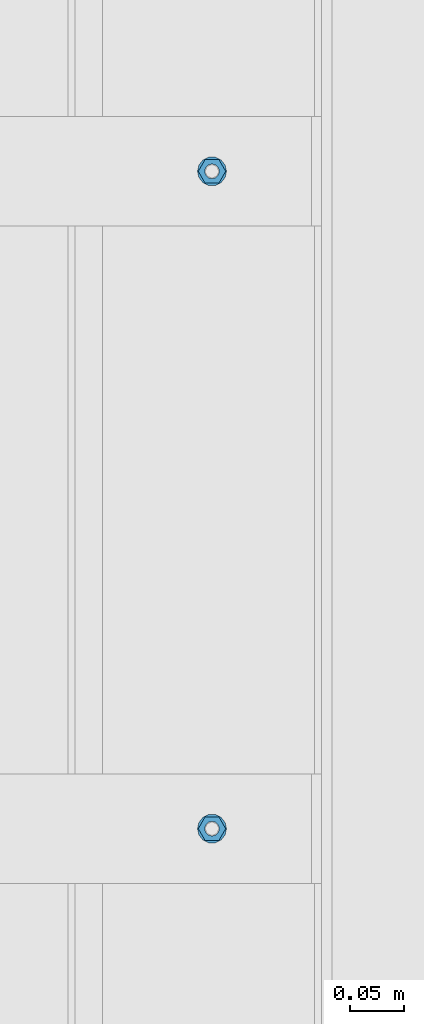
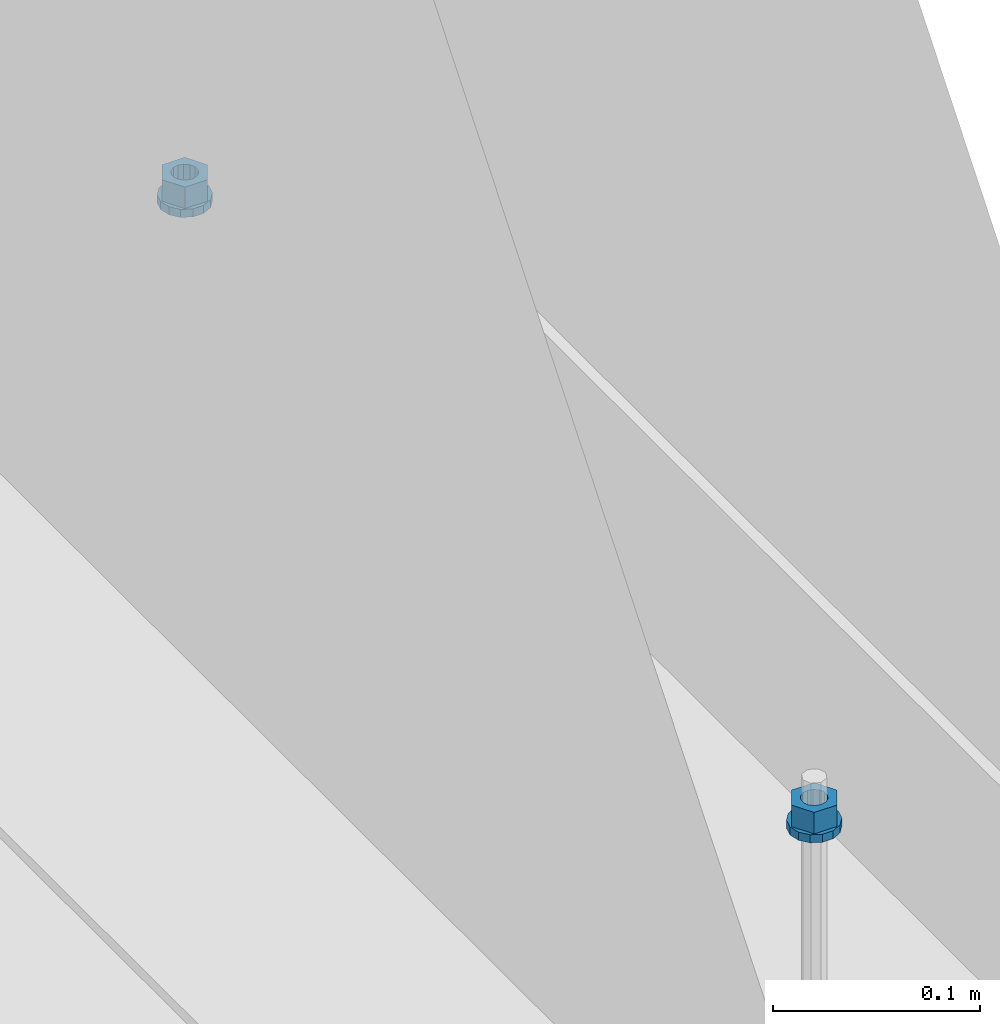
# One storey, part 616 of 1179: 4 columns, 1 element without a shape of its own.
"""IFC2X3 building model written with IfcOpenShell, lengths in millimetres."""

from ifc_helpers import new_model, si_unit, frame, origin_with_axes, place, context, subcontext, project, spatial, faceted_brep, material, type_object, element, aggregate, save


model = new_model("IFC2X3")

# Units and contexts
model_context = context("Model", 3, precision=1e-05, world=origin_with_axes())
body_context = subcontext(model_context, "Body", "Model", "MODEL_VIEW")
ifc_project = project(units=[si_unit("LENGTHUNIT", "METRE", prefix="MILLI"), si_unit("AREAUNIT", "SQUARE_METRE"), si_unit("VOLUMEUNIT", "CUBIC_METRE"), si_unit("MASSUNIT", "GRAM", prefix="KILO"), si_unit("TIMEUNIT", "SECOND"), si_unit("PLANEANGLEUNIT", "RADIAN"), si_unit("SOLIDANGLEUNIT", "STERADIAN"), si_unit("THERMODYNAMICTEMPERATUREUNIT", "DEGREE_CELSIUS"), si_unit("LUMINOUSINTENSITYUNIT", "LUMEN")], contexts=[model_context])

# Site, building, storey
site_placement = place(None, origin_with_axes())
site = spatial("IfcSite", under=ifc_project, at=site_placement, CompositionType="ELEMENT")
building_placement = place(site_placement, origin_with_axes())
building = spatial("IfcBuilding", under=site, at=building_placement, Name="Undefined", CompositionType="ELEMENT")
storey_placement = place(building_placement, origin_with_axes())
storey = spatial("IfcBuildingStorey", under=building, at=storey_placement, Name="Undefined", CompositionType="ELEMENT", Elevation=0.0)

# Assembly, columns
assembly_placement = place(storey_placement, origin_with_axes())
assembly = element("IfcElementAssembly", 1, at=assembly_placement, inside=storey, Name="BEAM", AssemblyPlace="NOTDEFINED", PredefinedType="RIGID_FRAME")
ifc_material = material(Name="STEEL/A307")
column_type_1 = type_object("IfcColumnType", Name="1/2_WASHER", PredefinedType="NOTDEFINED")
column_1_placement = place(assembly_placement, frame((24638.0, 15354.3, 4235.45), z_axis=(0.0, 1.0, 0.0), x_axis=(0.0, 0.0, 1.0)))
column_1 = element("IfcColumn", 2, at=column_1_placement, type_object=column_type_1, material=ifc_material, Name="WASHER", ObjectType="1/2_WASHER", context=body_context, shape_type="Brep", body=[
    faceted_brep([(0.0, -13.4899997711182, 0.0), (0.0, -12.1540698217868, -5.85309154138758), (4.76249999999891, -12.1540698217868, -5.85309154138758), (4.76249999999891, -13.4899997711182, 0.0), (0.0, -8.41087728436833, -10.5469065195466), (4.76249999999891, -8.41087728436833, -10.5469065195466), (0.0, -3.00180734814057, -13.1517773121896), (4.76249999999891, -3.00180734814057, -13.1517773121896), (0.0, 3.00180734814057, -13.1517773121896), (4.76249999999891, 3.00180734814057, -13.1517773121896), (0.0, 8.41087728436833, -10.5469065195466), (4.76249999999891, 8.41087728436833, -10.5469065195466), (0.0, 12.1540698217868, -5.85309154138758), (4.76249999999891, 12.1540698217868, -5.85309154138758), (0.0, 13.4899997711182, 0.0), (4.76249999999891, 13.4899997711182, 0.0), (0.0, 12.1540698217868, 5.85309154138758), (4.76249999999891, 12.1540698217868, 5.85309154138758), (0.0, 8.41087728436833, 10.5469065195466), (4.76249999999891, 8.41087728436833, 10.5469065195466), (0.0, 3.00180734814057, 13.1517773121896), (4.76249999999891, 3.00180734814057, 13.1517773121896), (0.0, -3.00180734814057, 13.1517773121896), (4.76249999999891, -3.00180734814057, 13.1517773121896), (0.0, -8.41087728436833, 10.5469065195466), (4.76249999999891, -8.41087728436833, 10.5469065195466), (0.0, -12.1540698217868, 5.85309154138758), (4.76249999999891, -12.1540698217868, 5.85309154138758), (0.0, 0.0, 6.75), (0.0, 2.9287152390425, 6.08153985834178), (4.76249999999891, 2.9287152390425, 6.08153985834178), (4.76249999999891, 0.0, 6.75), (0.0, 5.27736250665839, 4.2085561625463), (4.76249999999891, 5.27736250665839, 4.2085561625463), (0.0, 6.58076340722619, 1.50201630420543), (4.76249999999891, 6.58076340722619, 1.50201630420543), (0.0, 6.58076340722619, -1.50201630420543), (4.76249999999891, 6.58076340722619, -1.50201630420543), (0.0, 5.27736250665839, -4.2085561625463), (4.76249999999891, 5.27736250665839, -4.2085561625463), (0.0, 2.9287152390425, -6.08153985834088), (4.76249999999891, 2.9287152390425, -6.08153985834088), (0.0, 0.0, -6.75), (4.76249999999891, 0.0, -6.75), (0.0, -2.9287152390425, -6.08153985834178), (4.76249999999891, -2.9287152390425, -6.08153985834178), (0.0, -5.27736250665839, -4.2085561625463), (4.76249999999891, -5.27736250665839, -4.2085561625463), (0.0, -6.58076340722619, -1.50201630420543), (4.76249999999891, -6.58076340722619, -1.50201630420543), (0.0, -6.58076340722619, 1.50201630420543), (4.76249999999891, -6.58076340722619, 1.50201630420543), (0.0, -5.27736250665839, 4.2085561625463), (4.76249999999891, -5.27736250665839, 4.2085561625463), (0.0, -2.9287152390425, 6.08153985834088), (4.76249999999891, -2.9287152390425, 6.08153985834088)], [[[0, 1, 2, 3]], [[1, 4, 5, 2]], [[4, 6, 7, 5]], [[6, 8, 9, 7]], [[8, 10, 11, 9]], [[10, 12, 13, 11]], [[12, 14, 15, 13]], [[14, 16, 17, 15]], [[16, 18, 19, 17]], [[18, 20, 21, 19]], [[20, 22, 23, 21]], [[22, 24, 25, 23]], [[24, 26, 27, 25]], [[26, 0, 3, 27]], [[28, 29, 30, 31]], [[29, 32, 33, 30]], [[32, 34, 35, 33]], [[34, 36, 37, 35]], [[36, 38, 39, 37]], [[38, 40, 41, 39]], [[40, 42, 43, 41]], [[42, 44, 45, 43]], [[44, 46, 47, 45]], [[46, 48, 49, 47]], [[48, 50, 51, 49]], [[50, 52, 53, 51]], [[52, 54, 55, 53]], [[54, 28, 31, 55]], [[5, 7, 9, 11, 13, 15, 17, 19, 21, 23, 25, 27, 3, 2], [33, 35, 37, 39, 41, 43, 45, 47, 49, 51, 53, 55, 31, 30]], [[26, 24, 22, 20, 18, 16, 14, 12, 10, 8, 6, 4, 1, 0], [54, 52, 50, 48, 46, 44, 42, 40, 38, 36, 34, 32, 29, 28]]]),
])
column_2_placement = place(assembly_placement, frame((24638.0, 14744.7, 4235.45), z_axis=(0.0, 1.0, 0.0), x_axis=(0.0, 0.0, 1.0)))
column_2 = element("IfcColumn", 3, at=column_2_placement, type_object=column_type_1, material=ifc_material, Name="WASHER", ObjectType="1/2_WASHER", context=body_context, shape_type="Brep", body=[
    faceted_brep([(0.0, -13.4899997711182, 0.0), (0.0, -12.1540698217868, -5.85309154138758), (4.76249999999891, -12.1540698217868, -5.85309154138758), (4.76249999999891, -13.4899997711182, 0.0), (0.0, -8.41087728436833, -10.5469065195466), (4.76249999999891, -8.41087728436833, -10.5469065195466), (0.0, -3.00180734814057, -13.1517773121896), (4.76249999999891, -3.00180734814057, -13.1517773121896), (0.0, 3.00180734814057, -13.1517773121896), (4.76249999999891, 3.00180734814057, -13.1517773121896), (0.0, 8.41087728436833, -10.5469065195466), (4.76249999999891, 8.41087728436833, -10.5469065195466), (0.0, 12.1540698217868, -5.85309154138758), (4.76249999999891, 12.1540698217868, -5.85309154138758), (0.0, 13.4899997711182, 0.0), (4.76249999999891, 13.4899997711182, 0.0), (0.0, 12.1540698217868, 5.85309154138758), (4.76249999999891, 12.1540698217868, 5.85309154138758), (0.0, 8.41087728436833, 10.5469065195466), (4.76249999999891, 8.41087728436833, 10.5469065195466), (0.0, 3.00180734814057, 13.1517773121896), (4.76249999999891, 3.00180734814057, 13.1517773121896), (0.0, -3.00180734814057, 13.1517773121896), (4.76249999999891, -3.00180734814057, 13.1517773121896), (0.0, -8.41087728436833, 10.5469065195466), (4.76249999999891, -8.41087728436833, 10.5469065195466), (0.0, -12.1540698217868, 5.85309154138758), (4.76249999999891, -12.1540698217868, 5.85309154138758), (0.0, 0.0, 6.75), (0.0, 2.9287152390425, 6.08153985834178), (4.76249999999891, 2.9287152390425, 6.08153985834178), (4.76249999999891, 0.0, 6.75), (0.0, 5.27736250665839, 4.2085561625463), (4.76249999999891, 5.27736250665839, 4.2085561625463), (0.0, 6.58076340722619, 1.50201630420543), (4.76249999999891, 6.58076340722619, 1.50201630420543), (0.0, 6.58076340722619, -1.50201630420543), (4.76249999999891, 6.58076340722619, -1.50201630420543), (0.0, 5.27736250665839, -4.2085561625463), (4.76249999999891, 5.27736250665839, -4.2085561625463), (0.0, 2.9287152390425, -6.08153985834088), (4.76249999999891, 2.9287152390425, -6.08153985834088), (0.0, 0.0, -6.75), (4.76249999999891, 0.0, -6.75), (0.0, -2.9287152390425, -6.08153985834178), (4.76249999999891, -2.9287152390425, -6.08153985834178), (0.0, -5.27736250665839, -4.2085561625463), (4.76249999999891, -5.27736250665839, -4.2085561625463), (0.0, -6.58076340722619, -1.50201630420543), (4.76249999999891, -6.58076340722619, -1.50201630420543), (0.0, -6.58076340722619, 1.50201630420543), (4.76249999999891, -6.58076340722619, 1.50201630420543), (0.0, -5.27736250665839, 4.2085561625463), (4.76249999999891, -5.27736250665839, 4.2085561625463), (0.0, -2.9287152390425, 6.08153985834088), (4.76249999999891, -2.9287152390425, 6.08153985834088)], [[[0, 1, 2, 3]], [[1, 4, 5, 2]], [[4, 6, 7, 5]], [[6, 8, 9, 7]], [[8, 10, 11, 9]], [[10, 12, 13, 11]], [[12, 14, 15, 13]], [[14, 16, 17, 15]], [[16, 18, 19, 17]], [[18, 20, 21, 19]], [[20, 22, 23, 21]], [[22, 24, 25, 23]], [[24, 26, 27, 25]], [[26, 0, 3, 27]], [[28, 29, 30, 31]], [[29, 32, 33, 30]], [[32, 34, 35, 33]], [[34, 36, 37, 35]], [[36, 38, 39, 37]], [[38, 40, 41, 39]], [[40, 42, 43, 41]], [[42, 44, 45, 43]], [[44, 46, 47, 45]], [[46, 48, 49, 47]], [[48, 50, 51, 49]], [[50, 52, 53, 51]], [[52, 54, 55, 53]], [[54, 28, 31, 55]], [[5, 7, 9, 11, 13, 15, 17, 19, 21, 23, 25, 27, 3, 2], [33, 35, 37, 39, 41, 43, 45, 47, 49, 51, 53, 55, 31, 30]], [[26, 24, 22, 20, 18, 16, 14, 12, 10, 8, 6, 4, 1, 0], [54, 52, 50, 48, 46, 44, 42, 40, 38, 36, 34, 32, 29, 28]]]),
])
column_type_2 = type_object("IfcColumnType", Name="1/2_HEAVY_HEX_NUT", PredefinedType="NOTDEFINED")
column_3_placement = place(assembly_placement, frame((24638.0, 15354.3, 4240.2125), z_axis=(0.0, 1.0, 0.0), x_axis=(0.0, 0.0, 1.0)))
column_3 = element("IfcColumn", 4, at=column_3_placement, type_object=column_type_2, material=ifc_material, Name="NUT", ObjectType="1/2_HEAVY_HEX_NUT", context=body_context, shape_type="Brep", body=[
    faceted_brep([(0.0, -12.7, 0.0), (0.0, -6.34999990463257, -11.0), (12.7000000000007, -6.34999990463257, -11.0), (12.7000000000007, -12.6999998092651, 0.0), (0.0, 6.34999990463257, -11.0), (12.7000000000007, 6.34999990463257, -11.0), (0.0, 12.7, 0.0), (12.7000000000007, 12.6999998092651, 0.0), (0.0, 6.34999990463257, 11.0), (12.7000000000007, 6.34999990463257, 11.0), (0.0, -6.34999990463257, 11.0), (12.7000000000007, -6.34999990463257, 11.0), (0.0, 0.0, 6.75), (0.0, 2.9287152390425, 6.08153985834178), (12.7000000000007, 2.9287152390425, 6.08153985834178), (12.7000000000007, 0.0, 6.75), (0.0, 5.27736250665839, 4.2085561625463), (12.7000000000007, 5.27736250665839, 4.2085561625463), (0.0, 6.58076340722619, 1.50201630420543), (12.7000000000007, 6.58076340722619, 1.50201630420543), (0.0, 6.58076340722619, -1.50201630420543), (12.7000000000007, 6.58076340722619, -1.50201630420543), (0.0, 5.27736250665839, -4.2085561625463), (12.7000000000007, 5.27736250665839, -4.2085561625463), (0.0, 2.9287152390425, -6.08153985834088), (12.7000000000007, 2.9287152390425, -6.08153985834088), (0.0, 0.0, -6.75), (12.7000000000007, 0.0, -6.75), (0.0, -2.9287152390425, -6.08153985834178), (12.7000000000007, -2.9287152390425, -6.08153985834178), (0.0, -5.27736250665839, -4.2085561625463), (12.7000000000007, -5.27736250665839, -4.2085561625463), (0.0, -6.58076340722619, -1.50201630420543), (12.7000000000007, -6.58076340722619, -1.50201630420543), (0.0, -6.58076340722619, 1.50201630420543), (12.7000000000007, -6.58076340722619, 1.50201630420543), (0.0, -5.27736250665839, 4.2085561625463), (12.7000000000007, -5.27736250665839, 4.2085561625463), (0.0, -2.9287152390425, 6.08153985834088), (12.7000000000007, -2.9287152390425, 6.08153985834088)], [[[0, 1, 2, 3]], [[1, 4, 5, 2]], [[4, 6, 7, 5]], [[6, 8, 9, 7]], [[8, 10, 11, 9]], [[10, 0, 3, 11]], [[12, 13, 14, 15]], [[13, 16, 17, 14]], [[16, 18, 19, 17]], [[18, 20, 21, 19]], [[20, 22, 23, 21]], [[22, 24, 25, 23]], [[24, 26, 27, 25]], [[26, 28, 29, 27]], [[28, 30, 31, 29]], [[30, 32, 33, 31]], [[32, 34, 35, 33]], [[34, 36, 37, 35]], [[36, 38, 39, 37]], [[38, 12, 15, 39]], [[5, 7, 9, 11, 3, 2], [17, 19, 21, 23, 25, 27, 29, 31, 33, 35, 37, 39, 15, 14]], [[10, 8, 6, 4, 1, 0], [38, 36, 34, 32, 30, 28, 26, 24, 22, 20, 18, 16, 13, 12]]]),
])
column_4_placement = place(assembly_placement, frame((24638.0, 14744.7, 4240.2125), z_axis=(0.0, 1.0, 0.0), x_axis=(0.0, 0.0, 1.0)))
column_4 = element("IfcColumn", 5, at=column_4_placement, type_object=column_type_2, material=ifc_material, Name="NUT", ObjectType="1/2_HEAVY_HEX_NUT", context=body_context, shape_type="Brep", body=[
    faceted_brep([(0.0, -12.7, 0.0), (0.0, -6.34999990463257, -11.0), (12.7000000000007, -6.34999990463257, -11.0), (12.7000000000007, -12.6999998092651, 0.0), (0.0, 6.34999990463257, -11.0), (12.7000000000007, 6.34999990463257, -11.0), (0.0, 12.7, 0.0), (12.7000000000007, 12.6999998092651, 0.0), (0.0, 6.34999990463257, 11.0), (12.7000000000007, 6.34999990463257, 11.0), (0.0, -6.34999990463257, 11.0), (12.7000000000007, -6.34999990463257, 11.0), (0.0, 0.0, 6.75), (0.0, 2.9287152390425, 6.08153985834178), (12.7000000000007, 2.9287152390425, 6.08153985834178), (12.7000000000007, 0.0, 6.75), (0.0, 5.27736250665839, 4.2085561625463), (12.7000000000007, 5.27736250665839, 4.2085561625463), (0.0, 6.58076340722619, 1.50201630420543), (12.7000000000007, 6.58076340722619, 1.50201630420543), (0.0, 6.58076340722619, -1.50201630420543), (12.7000000000007, 6.58076340722619, -1.50201630420543), (0.0, 5.27736250665839, -4.2085561625463), (12.7000000000007, 5.27736250665839, -4.2085561625463), (0.0, 2.9287152390425, -6.08153985834088), (12.7000000000007, 2.9287152390425, -6.08153985834088), (0.0, 0.0, -6.75), (12.7000000000007, 0.0, -6.75), (0.0, -2.9287152390425, -6.08153985834178), (12.7000000000007, -2.9287152390425, -6.08153985834178), (0.0, -5.27736250665839, -4.2085561625463), (12.7000000000007, -5.27736250665839, -4.2085561625463), (0.0, -6.58076340722619, -1.50201630420543), (12.7000000000007, -6.58076340722619, -1.50201630420543), (0.0, -6.58076340722619, 1.50201630420543), (12.7000000000007, -6.58076340722619, 1.50201630420543), (0.0, -5.27736250665839, 4.2085561625463), (12.7000000000007, -5.27736250665839, 4.2085561625463), (0.0, -2.9287152390425, 6.08153985834088), (12.7000000000007, -2.9287152390425, 6.08153985834088)], [[[0, 1, 2, 3]], [[1, 4, 5, 2]], [[4, 6, 7, 5]], [[6, 8, 9, 7]], [[8, 10, 11, 9]], [[10, 0, 3, 11]], [[12, 13, 14, 15]], [[13, 16, 17, 14]], [[16, 18, 19, 17]], [[18, 20, 21, 19]], [[20, 22, 23, 21]], [[22, 24, 25, 23]], [[24, 26, 27, 25]], [[26, 28, 29, 27]], [[28, 30, 31, 29]], [[30, 32, 33, 31]], [[32, 34, 35, 33]], [[34, 36, 37, 35]], [[36, 38, 39, 37]], [[38, 12, 15, 39]], [[5, 7, 9, 11, 3, 2], [17, 19, 21, 23, 25, 27, 29, 31, 33, 35, 37, 39, 15, 14]], [[10, 8, 6, 4, 1, 0], [38, 36, 34, 32, 30, 28, 26, 24, 22, 20, 18, 16, 13, 12]]]),
])
aggregate(assembly, [column_1, column_3, column_2, column_4])

save(model, "model.ifc")
